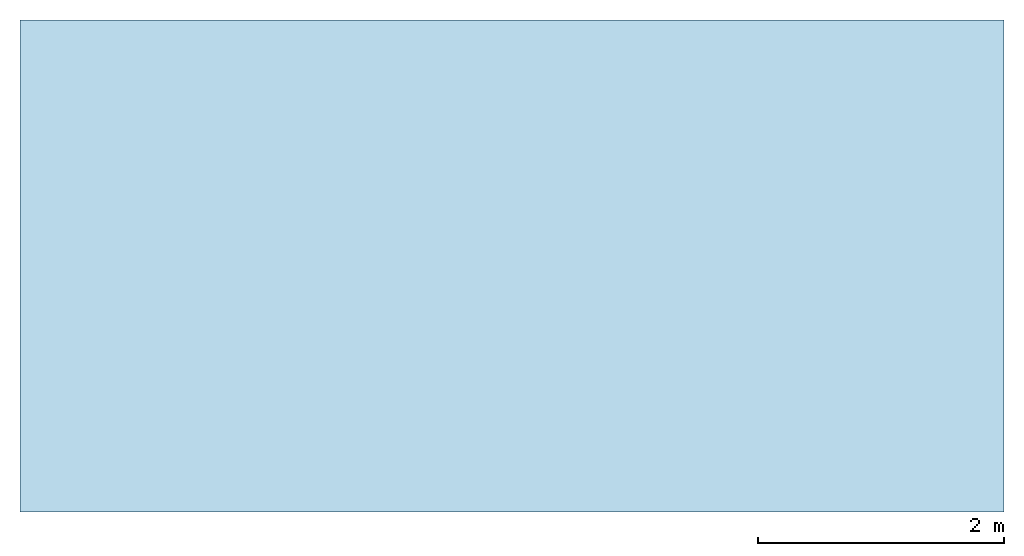
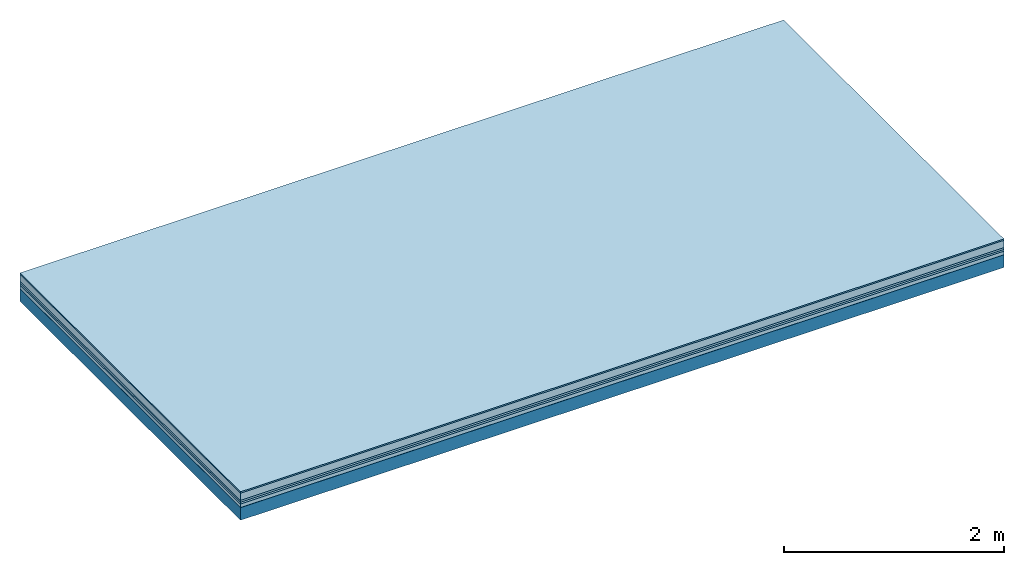
# One storey: 6 plates, 1 member, 1 element without a shape of its own.
"""IFC4 building model written with IfcOpenShell, lengths in metres."""

from ifc_helpers import new_model, si_unit, derived_unit, direction, frame, frame_2d, origin, origin_with_axes, place, context, project, spatial, rectangle, extrude, material, layer, layer_set, type_object, element, aggregate, save


model = new_model("IFC4")

# Units and contexts
plan_context = context("Plan", 3, precision=1e-05, world=origin(), true_north=direction((0.0, 1.0)))
model_context = context("Model", 3, precision=1e-05, world=origin(), true_north=direction((0.0, 1.0)))
ifc_project = project(units=[si_unit("LENGTHUNIT", "METRE"), derived_unit("SOUNDPRESSUREUNIT", [(si_unit("PRESSUREUNIT", "PASCAL", prefix="MICRO"), 0)]), si_unit("ENERGYUNIT", "JOULE", prefix="MEGA"), si_unit("MASSUNIT", "GRAM", prefix="KILO"), derived_unit("THERMALTRANSMITTANCEUNIT", [(si_unit("POWERUNIT", "WATT"), 1), (si_unit("AREAUNIT", "SQUARE_METRE"), -1), (si_unit("THERMODYNAMICTEMPERATUREUNIT", "KELVIN"), -1)]), derived_unit("AREADENSITYUNIT", [(si_unit("MASSUNIT", "GRAM", prefix="KILO"), 1), (si_unit("AREAUNIT", "SQUARE_METRE"), -1)]), derived_unit("USERDEFINED", [(si_unit("ENERGYUNIT", "JOULE", prefix="MEGA"), 1), (si_unit("AREAUNIT", "SQUARE_METRE"), -1)])], contexts=[plan_context, model_context])

# Site, building, storey
site = spatial("IfcSite", under=ifc_project)
building_placement = place(None, origin())
building = spatial("IfcBuilding", under=site, at=building_placement)
storey_placement = place(building_placement, origin())
storey = spatial("IfcBuildingStorey", under=building, at=storey_placement)

# Slab, member, plates
ifc_material_1 = material(Category="11.013")
ifc_layer_1 = layer(ifc_material_1, 0.015, Name="Flooring")
ifc_material_2 = material(Name="Cement screed", Category="04.006")
ifc_layer_2 = layer(ifc_material_2, 0.08, Name="On-material")
ifc_material_3 = material(Name="Wood fiber generic product", Category="10.009")
ifc_layer_3 = layer(ifc_material_3, 0.02, Name="Impact sound insulation")
ifc_material_4 = material()
ifc_layer_4 = layer(ifc_material_4, 0.02, Name="Additional insulation")
ifc_material_5 = material(Name="Cement panels, glued on sub-floor", Category="02.007")
ifc_layer_5 = layer(ifc_material_5, 0.04, Name="on Supporting structure")
ifc_material_6 = material(Name="protection", Category="09.007")
ifc_layer_6 = layer(ifc_material_6, 0.0005, Name="Sub-floor")
ifc_material_7 = material(Name="no composite action")
ifc_layer_7 = layer(ifc_material_7, 0.0, Name="Bond")
ifc_layer_8 = layer(None, 0.14, Name="Supporting structure")
ifc_layer_set = layer_set([ifc_layer_1, ifc_layer_2, ifc_layer_3, ifc_layer_4, ifc_layer_5, ifc_layer_6, ifc_layer_7, ifc_layer_8])
slab_type = type_object("IfcSlabType", Name="A2088", PredefinedType="NOTDEFINED", material=ifc_layer_set)
slab_placement = place(None, frame((0.0, 0.0, 0.0), z_axis=(0.0, 0.0, -1.0), x_axis=(1.0, 0.0, 0.0)))
slab = element("IfcSlab", 1, at=slab_placement, inside=storey, type_object=slab_type, material=ifc_layer_set, Name="Slab #1")
ifc_material_8 = material(Name="Solid timber panel")
member_placement = place(slab_placement, origin())
member = element("IfcMember", 2, at=member_placement, material=ifc_material_8, Name="Supporting structure", context=plan_context, shape_type="SweptSolid", body=[
    extrude(rectangle(XDim=1.0, YDim=0.14, at=frame_2d((0.5, 0.07), x_axis=(1.0, 0.0))), frame((0.0, 4.0, 0.1755), z_axis=(0.0, -1.0, 0.0), x_axis=(1.0, 0.0, 0.0)), (0.0, 0.0, 1.0), 4.0),
    extrude(rectangle(XDim=1.0, YDim=0.14, at=frame_2d((0.5, 0.07), x_axis=(1.0, 0.0))), frame((1.0, 4.0, 0.1755), z_axis=(0.0, -1.0, 0.0), x_axis=(1.0, 0.0, 0.0)), (0.0, 0.0, 1.0), 4.0),
    extrude(rectangle(XDim=1.0, YDim=0.14, at=frame_2d((0.5, 0.07), x_axis=(1.0, 0.0))), frame((2.0, 4.0, 0.1755), z_axis=(0.0, -1.0, 0.0), x_axis=(1.0, 0.0, 0.0)), (0.0, 0.0, 1.0), 4.0),
    extrude(rectangle(XDim=1.0, YDim=0.14, at=frame_2d((0.5, 0.07), x_axis=(1.0, 0.0))), frame((3.0, 4.0, 0.1755), z_axis=(0.0, -1.0, 0.0), x_axis=(1.0, 0.0, 0.0)), (0.0, 0.0, 1.0), 4.0),
    extrude(rectangle(XDim=1.0, YDim=0.14, at=frame_2d((0.5, 0.07), x_axis=(1.0, 0.0))), frame((4.0, 4.0, 0.1755), z_axis=(0.0, -1.0, 0.0), x_axis=(1.0, 0.0, 0.0)), (0.0, 0.0, 1.0), 4.0),
    extrude(rectangle(XDim=1.0, YDim=0.14, at=frame_2d((0.5, 0.07), x_axis=(1.0, 0.0))), frame((5.0, 4.0, 0.1755), z_axis=(0.0, -1.0, 0.0), x_axis=(1.0, 0.0, 0.0)), (0.0, 0.0, 1.0), 4.0),
    extrude(rectangle(XDim=1.0, YDim=0.14, at=frame_2d((0.5, 0.07), x_axis=(1.0, 0.0))), frame((6.0, 4.0, 0.1755), z_axis=(0.0, -1.0, 0.0), x_axis=(1.0, 0.0, 0.0)), (0.0, 0.0, 1.0), 4.0),
    extrude(rectangle(XDim=1.0, YDim=0.14, at=frame_2d((0.5, 0.07), x_axis=(1.0, 0.0))), frame((7.0, 4.0, 0.1755), z_axis=(0.0, -1.0, 0.0), x_axis=(1.0, 0.0, 0.0)), (0.0, 0.0, 1.0), 4.0),
])
plate_1_placement = place(slab_placement, origin())
plate_1 = element("IfcPlate", 3, at=plate_1_placement, material=ifc_material_1, Name="Flooring", context=plan_context, shape_type="SweptSolid", body=[
    extrude(rectangle(XDim=8.0, YDim=4.0, at=frame_2d((4.0, 2.0), x_axis=(1.0, 0.0))), origin_with_axes(), (0.0, 0.0, 1.0), 0.015),
])
plate_2_placement = place(slab_placement, origin())
plate_2 = element("IfcPlate", 4, at=plate_2_placement, material=ifc_material_2, Name="On-material", context=plan_context, shape_type="SweptSolid", body=[
    extrude(rectangle(XDim=8.0, YDim=4.0, at=frame_2d((4.0, 2.0), x_axis=(1.0, 0.0))), frame((0.0, 0.0, 0.015), z_axis=(0.0, 0.0, 1.0), x_axis=(1.0, 0.0, 0.0)), (0.0, 0.0, 1.0), 0.08),
])
plate_3_placement = place(slab_placement, origin())
plate_3 = element("IfcPlate", 5, at=plate_3_placement, material=ifc_material_3, Name="Impact sound insulation", context=plan_context, shape_type="SweptSolid", body=[
    extrude(rectangle(XDim=8.0, YDim=4.0, at=frame_2d((4.0, 2.0), x_axis=(1.0, 0.0))), frame((0.0, 0.0, 0.095), z_axis=(0.0, 0.0, 1.0), x_axis=(1.0, 0.0, 0.0)), (0.0, 0.0, 1.0), 0.02),
])
plate_4_placement = place(slab_placement, origin())
plate_4 = element("IfcPlate", 6, at=plate_4_placement, material=ifc_material_4, Name="Additional insulation", context=plan_context, shape_type="SweptSolid", body=[
    extrude(rectangle(XDim=8.0, YDim=4.0, at=frame_2d((4.0, 2.0), x_axis=(1.0, 0.0))), frame((0.0, 0.0, 0.115), z_axis=(0.0, 0.0, 1.0), x_axis=(1.0, 0.0, 0.0)), (0.0, 0.0, 1.0), 0.02),
])
plate_5_placement = place(slab_placement, origin())
plate_5 = element("IfcPlate", 7, at=plate_5_placement, material=ifc_material_5, Name="on Supporting structure", context=plan_context, shape_type="SweptSolid", body=[
    extrude(rectangle(XDim=8.0, YDim=4.0, at=frame_2d((4.0, 2.0), x_axis=(1.0, 0.0))), frame((0.0, 0.0, 0.135), z_axis=(0.0, 0.0, 1.0), x_axis=(1.0, 0.0, 0.0)), (0.0, 0.0, 1.0), 0.04),
])
plate_6_placement = place(slab_placement, origin())
plate_6 = element("IfcPlate", 8, at=plate_6_placement, material=ifc_material_6, Name="Sub-floor", context=plan_context, shape_type="SweptSolid", body=[
    extrude(rectangle(XDim=8.0, YDim=4.0, at=frame_2d((4.0, 2.0), x_axis=(1.0, 0.0))), frame((0.0, 0.0, 0.175), z_axis=(0.0, 0.0, 1.0), x_axis=(1.0, 0.0, 0.0)), (0.0, 0.0, 1.0), 0.0005),
])
aggregate(slab, [plate_1, plate_2, plate_3, plate_4, plate_5, plate_6, member])

save(model, "model.ifc")
